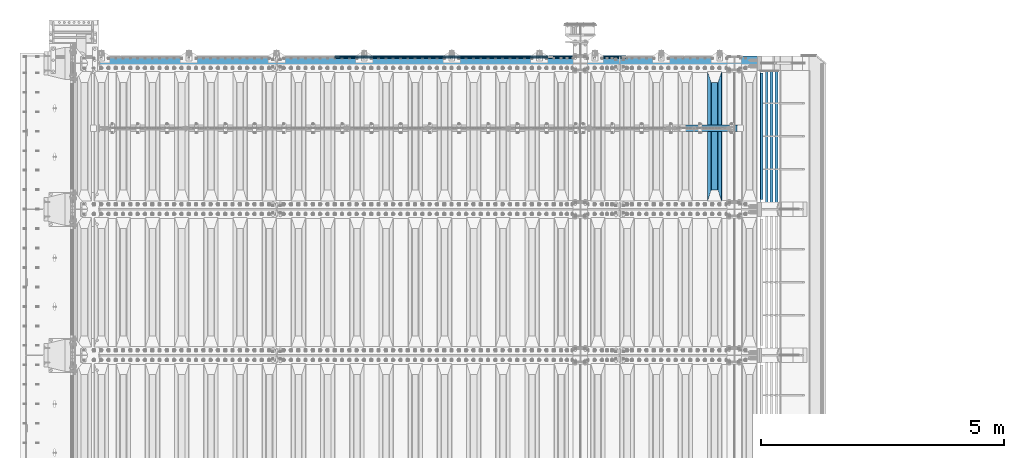
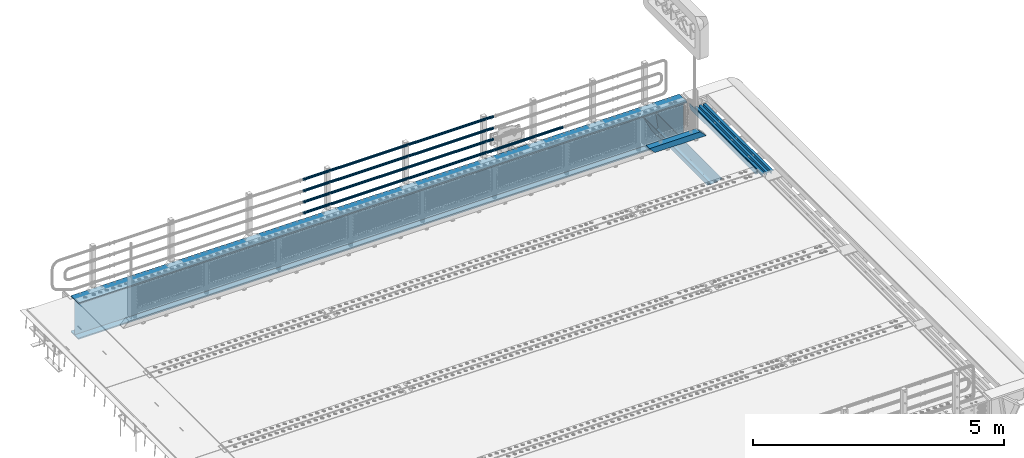
# One storey, part 126 of 240: 12 beams.
"""IFC2X3 building model written with IfcOpenShell, lengths in millimetres."""

import ifcopenshell
import ifcopenshell.guid

model = None  # the IFC model being written
_history = None  # IfcOwnerHistory: only IFC2X3 demands one
_inside = {}  # id of a spatial element -> (the spatial element, [elements in it])
_under = {}  # id of a project, library or spatial element -> (it, [spatial elements below it])
_declared = {}  # id of a project -> (the project, [libraries it declares])
_typed = {}  # id of a type object -> (the type object, [elements of that type])
_made_of = {}  # id of a material, layer set ... -> (it, [elements and type objects made of it])


def new_model(schema):
    """Start an empty IFC model of exactly this schema.

    Asked for "IFC4X3", IfcOpenShell would pick the latest addendum, in which some entities
    have other attributes; the version numbers below select the first issue.
    IFC2X3 requires an IfcOwnerHistory on every rooted entity: one is made here for all.
    """
    global model, _history
    if schema == "IFC4X3":
        model = ifcopenshell.file(schema_version=(4, 3, 0, 0))
    else:
        model = ifcopenshell.file(schema=schema)
    _inside.clear()
    _under.clear()
    _declared.clear()
    _typed.clear()
    _made_of.clear()
    _history = None
    if model.schema == "IFC2X3":
        org = make("IfcOrganization", Name="unknown")
        user = make(
            "IfcPersonAndOrganization",
            ThePerson=make("IfcPerson", FamilyName="unknown"),
            TheOrganization=org,
        )
        app = make(
            "IfcApplication",
            ApplicationDeveloper=org,
            Version="unknown",
            ApplicationFullName="unknown",
            ApplicationIdentifier="unknown",
        )
        _history = make(
            "IfcOwnerHistory",
            OwningUser=user,
            OwningApplication=app,
            ChangeAction="ADDED",
            CreationDate=0,
        )
    return model


def make(cls, **values):
    """One entity of the class cls with the attributes given. An attribute that is None is left unset."""
    return model.create_entity(
        cls, **{name: value for name, value in values.items() if value is not None}
    )


def rooted(cls, **values):
    """An entity with a GlobalId (a new one), such as an element, a storey or a relation."""
    return make(cls, GlobalId=ifcopenshell.guid.new(), OwnerHistory=_history, **values)


def si_unit(unit_type, name, prefix=None):
    """IfcSIUnit, for example si_unit("LENGTHUNIT", "METRE", prefix="MILLI")."""
    return make("IfcSIUnit", UnitType=unit_type, Prefix=prefix, Name=name)


def assignment(units):
    """IfcUnitAssignment: the units of a project."""
    return None if units is None else make("IfcUnitAssignment", Units=units)


def point(xyz):
    """IfcCartesianPoint."""
    return None if xyz is None else make("IfcCartesianPoint", Coordinates=xyz)


def direction(xyz):
    """IfcDirection."""
    return None if xyz is None else make("IfcDirection", DirectionRatios=xyz)


def frame(location, z_axis=None, x_axis=None):
    """IfcAxis2Placement3D, a coordinate frame: its origin and axes. An axis left out is left unset."""
    return make(
        "IfcAxis2Placement3D",
        Location=point(location),
        Axis=direction(z_axis),
        RefDirection=direction(x_axis),
    )


def origin_with_axes():
    """The frame at (0, 0, 0) with the z axis (0, 0, 1) and the x axis (1, 0, 0) written out."""
    return frame((0.0, 0.0, 0.0), z_axis=(0.0, 0.0, 1.0), x_axis=(1.0, 0.0, 0.0))


def place(relative_to, where):
    """IfcLocalPlacement: puts the frame where relative to a parent placement (None: the world)."""
    return make(
        "IfcLocalPlacement", PlacementRelTo=relative_to, RelativePlacement=where
    )


def context(
    kind, dimensions, precision=None, world=None, true_north=None, identifier=None
):
    """IfcGeometricRepresentationContext, for example the 3D "Model" context."""
    return make(
        "IfcGeometricRepresentationContext",
        ContextIdentifier=identifier,
        ContextType=kind,
        CoordinateSpaceDimension=dimensions,
        Precision=precision,
        WorldCoordinateSystem=world,
        TrueNorth=true_north,
    )


def subcontext(parent, identifier, kind, view, scale=None):
    """IfcGeometricRepresentationSubContext, for example "Body" below "Model"."""
    return make(
        "IfcGeometricRepresentationSubContext",
        ContextIdentifier=identifier,
        ContextType=kind,
        ParentContext=parent,
        TargetScale=scale,
        TargetView=view,
    )


def project(units=None, contexts=None):
    """IfcProject with its units and contexts."""
    return rooted(
        "IfcProject",
        Name="project",
        RepresentationContexts=contexts,
        UnitsInContext=assignment(units),
    )


def spatial(cls, under=None, at=None, **own):
    """A site, building, storey or space (cls), placed at a placement, below another one or the project."""
    s = rooted(cls, ObjectPlacement=at, **own)
    if under is not None:
        _under.setdefault(under.id(), (under, []))[1].append(s)
    return s


def faces_of(points, faces, orient=None, outer=None):
    """IfcFace entities. A face is a list of loops; a loop is a list of indices into points, from 0.

    orient and outer hold one flag for each loop. By default every Orientation is true, the
    first loop of a face is its IfcFaceOuterBound and the others are IfcFaceBound.
    """
    made = []
    for i, loops in enumerate(faces):
        bounds = []
        for j, loop in enumerate(loops):
            is_outer = j == 0 if outer is None else outer[i][j]
            bounds.append(
                make(
                    "IfcFaceOuterBound" if is_outer else "IfcFaceBound",
                    Bound=make("IfcPolyLoop", Polygon=[points[k] for k in loop]),
                    Orientation=True if orient is None else orient[i][j],
                )
            )
        made.append(make("IfcFace", Bounds=bounds))
    return made


def faceted_brep(points, faces, orient=None, outer=None, voids=None):
    """IfcFacetedBrep: a solid bounded by flat faces; with voids (closed shells), ...WithVoids."""
    shared = [point(p) for p in points]
    hull = make("IfcClosedShell", CfsFaces=faces_of(shared, faces, orient, outer))
    if voids is None:
        return make("IfcFacetedBrep", Outer=hull)
    return make(
        "IfcFacetedBrepWithVoids",
        Outer=hull,
        Voids=[
            make(cls, CfsFaces=faces_of(shared, fs, o, b)) for cls, fs, o, b in voids
        ],
    )


def shape(context_of_items, identifier, shape_type, items):
    """IfcShapeRepresentation: the items that make up one representation, for example the "Body"."""
    return make(
        "IfcShapeRepresentation",
        ContextOfItems=context_of_items,
        RepresentationIdentifier=identifier,
        RepresentationType=shape_type,
        Items=items,
    )


def material(Name=None, Category=None):
    """IfcMaterial."""
    return make("IfcMaterial", Name=Name, Category=Category)


def made_of(thing, what):
    """Note that an element or type object is made of a material, layer set ...; save() writes the relation."""
    if what is not None:
        _made_of.setdefault(what.id(), (what, []))[1].append(thing)
    return thing


def type_object(cls, material=None, **own):
    """A type object (cls), such as IfcWallType, which elements share."""
    return made_of(rooted(cls, **own), material)


def element(
    cls,
    number,
    at=None,
    inside=None,
    cuts=None,
    type_object=None,
    material=None,
    context=None,
    identifier="Body",
    shape_type=None,
    held_by="IfcProductDefinitionShape",
    body=None,
    shapes=None,
    **own,
):
    """One element of the class cls, such as IfcWall. Its Tag is "e" and its number.

    at: its placement. inside: the storey or other place that contains it. cuts: it is an
    opening in that element (IfcRelVoidsElement). A single representation is given by context,
    identifier, shape_type and body (its items); several are given by shapes. held_by: the class
    of the entity that holds the representations. save() writes the other relations.
    """
    e = rooted(cls, Tag="e%d" % number, ObjectPlacement=at, **own)
    if body is not None:
        shapes = [shape(context, identifier, shape_type, body)]
    if shapes is not None:
        e.Representation = make(held_by, Representations=shapes)
    if inside is not None:
        _inside.setdefault(inside.id(), (inside, []))[1].append(e)
    if cuts is not None:
        rooted(
            "IfcRelVoidsElement", RelatingBuildingElement=cuts, RelatedOpeningElement=e
        )
    if type_object is not None:
        _typed.setdefault(type_object.id(), (type_object, []))[1].append(e)
    return made_of(e, material)


def aggregate(whole, parts):
    """IfcRelAggregates: a whole, such as a stair, and the parts it consists of."""
    return rooted("IfcRelAggregates", RelatingObject=whole, RelatedObjects=parts)


def save(model, path):
    """Write the relations noted so far, then the file.

    IfcRelAggregates (storeys below a building ...), IfcRelContainedInSpatialStructure (elements
    in a storey), IfcRelDefinesByType, IfcRelAssociatesMaterial and IfcRelDeclares: one each for
    every whole, place, type object, material and project.
    """
    for whole, parts in _under.values():
        aggregate(whole, parts)
    for where, things in _inside.values():
        rooted(
            "IfcRelContainedInSpatialStructure",
            RelatedElements=things,
            RelatingStructure=where,
        )
    for kind, things in _typed.values():
        rooted("IfcRelDefinesByType", RelatedObjects=things, RelatingType=kind)
    for what, things in _made_of.values():
        rooted("IfcRelAssociatesMaterial", RelatedObjects=things, RelatingMaterial=what)
    for by, libraries in _declared.values():
        rooted("IfcRelDeclares", RelatingContext=by, RelatedDefinitions=libraries)
    model.write(path)


model = new_model("IFC2X3")

# Units and contexts
model_context = context("Model", 3, precision=1e-05, world=origin_with_axes())
body_context = subcontext(model_context, "Body", "Model", "MODEL_VIEW")
ifc_project = project(units=[si_unit("LENGTHUNIT", "METRE", prefix="MILLI"), si_unit("AREAUNIT", "SQUARE_METRE"), si_unit("VOLUMEUNIT", "CUBIC_METRE"), si_unit("MASSUNIT", "GRAM", prefix="KILO"), si_unit("TIMEUNIT", "SECOND"), si_unit("PLANEANGLEUNIT", "RADIAN"), si_unit("SOLIDANGLEUNIT", "STERADIAN"), si_unit("THERMODYNAMICTEMPERATUREUNIT", "DEGREE_CELSIUS"), si_unit("LUMINOUSINTENSITYUNIT", "LUMEN")], contexts=[model_context])

# Site, building, storey
site_placement = place(None, origin_with_axes())
site = spatial("IfcSite", under=ifc_project, at=site_placement, CompositionType="ELEMENT")
building_placement = place(site_placement, origin_with_axes())
building = spatial("IfcBuilding", under=site, at=building_placement, Name="Standard", CompositionType="ELEMENT")
storey_placement = place(building_placement, origin_with_axes())
storey = spatial("IfcBuildingStorey", under=building, at=storey_placement, Name="Undefined", CompositionType="ELEMENT", Elevation=0.0)

# Beams
ifc_material_1 = material(Name="STEEL/S355N")
beam_type_1 = type_object("IfcBeamType", PredefinedType="NOTDEFINED")
beam_1_placement = place(storey_placement, frame((55600.0, 33175.0, -115.0), z_axis=(0.0, 0.0, 1.0), x_axis=(0.0, 1.0, 0.0)))
element("IfcBeam", 1, at=beam_1_placement, inside=storey, type_object=beam_type_1, material=ifc_material_1, context=body_context, shape_type="Brep", body=[
    faceted_brep([(0.0, 150.0, 115.0), (0.0, 143.690000000002, 115.0), (2650.00000000297, 143.690000000002, 115.0), (2650.00000000297, 150.0, 115.0), (2650.00000000297, 142.059565218406, 110.000000003094), (2650.00000000297, 148.369565218403, 110.000000003094), (2441.90079219209, -80.1103600731149, -98.0992078077845), (2437.7588105432, -77.5672621345584, -102.241189456673), (2434.06523489747, -74.4080125315522, -105.934765102404), (2430.9108609509, -70.7102721255724, -109.089139048974), (2428.37322971128, -66.5649389910031, -111.626770288588), (2426.51472138055, -62.0739139532889, -113.485278619323), (2425.38102192092, -57.3475956567636, -114.618978078955), (2424.99999999987, -52.5021667386536, -115.0), (2424.99999999987, 52.5021667386536, -115.0), (2425.38102192092, 57.3475956567636, -114.618978078955), (2426.51472138055, 62.0739139532889, -113.485278619323), (2428.37322971128, 66.5649389910031, -111.626770288588), (2430.9108609509, 70.7102721255724, -109.089139048974), (2434.06523489747, 74.4080125315522, -105.934765102404), (2437.7588105432, 77.5672621345584, -102.241189456673), (2441.90079219209, 80.1103600731149, -98.0992078077846), (2446.38936140512, 81.9747917625791, -93.6106385947584), (2448.2494850041, 76.2713538057287, -91.7505149957729), (2444.62967112263, 74.76777986261, -95.3703288772456), (2441.28936334127, 72.7168944282894, -98.710636658607), (2438.31067330439, 70.1691124903809, -101.689326695487), (2435.76682334748, 67.1870637758839, -104.233176652398), (2433.72034654134, 63.8440531834931, -106.279653458539), (2432.22154950042, 60.2222587982324, -107.778450499454), (2431.30727574265, 56.4107117849126, -108.692724257221), (2430.99999999987, 52.5031078186876, -109.0), (2430.99999999987, -52.5031078186876, -109.0), (2431.30727574265, -56.4107117849126, -108.692724257221), (2432.22154950042, -60.2222587982324, -107.778450499454), (2433.72034654134, -63.8440531834931, -106.279653458539), (2435.76682334748, -67.1870637758839, -104.233176652398), (2438.31067330439, -70.1691124903809, -101.689326695487), (2441.28936334127, -72.7168944282894, -98.7106366586071), (2444.62967112263, -74.76777986261, -95.3703288772457), (2448.2494850041, -76.2713538057287, -91.7505149957729), (2650.00000000297, -142.059565218406, 110.000000003094), (2650.00000000297, -148.369565218403, 110.000000003094), (2446.38936140512, -81.9747917625791, -93.6106385947584), (2650.00000000297, -143.690000000002, 115.0), (2650.00000000297, -150.0, 115.0), (0.0, -143.690000000002, 115.0), (0.0, -150.0, 115.0), (0.0, -148.369565218258, 110.000000002667), (203.610638597427, -81.9747917625791, -93.6106385947584), (208.09920781045, -80.1103600731149, -98.0992078077845), (212.241189459342, -77.5672621345584, -102.241189456673), (215.93476510507, -74.4080125315522, -105.934765102404), (219.089139051641, -70.7102721255724, -109.089139048974), (221.626770291256, -66.5649389910031, -111.626770288588), (223.485278621989, -62.0739139532889, -113.485278619323), (224.618978081624, -57.3475956567636, -114.618978078955), (225.000000002663, -52.5021667386536, -115.0), (225.000000002663, 52.5021667386536, -115.0), (224.618978081624, 57.3475956567636, -114.618978078955), (223.485278621989, 62.0739139532889, -113.485278619323), (221.626770291256, 66.5649389910031, -111.626770288588), (219.089139051641, 70.7102721255724, -109.089139048974), (215.93476510507, 74.4080125315522, -105.934765102404), (212.241189459342, 77.5672621345584, -102.241189456673), (208.09920781045, 80.1103600731149, -98.0992078077846), (203.610638597427, 81.9747917625791, -93.6106385947584), (0.0, 148.369565218258, 110.000000002667), (0.0, 142.05956521826, 110.000000002667), (201.750514998439, 76.2713538057287, -91.7505149957729), (205.370328879908, 74.76777986261, -95.3703288772456), (208.710636661275, 72.7168944282894, -98.710636658607), (211.689326698153, 70.1691124903809, -101.689326695487), (214.233176655063, 67.1870637758839, -104.233176652398), (216.279653461206, 63.8440531834931, -106.279653458539), (217.778450502123, 60.2222587982324, -107.778450499454), (218.692724259887, 56.4107117849126, -108.692724257221), (219.000000002667, 52.5031078186876, -109.0), (219.000000002667, -52.5031078186876, -109.0), (218.692724259887, -56.4107117849126, -108.692724257221), (217.778450502123, -60.2222587982324, -107.778450499454), (216.279653461206, -63.8440531834931, -106.279653458539), (214.233176655063, -67.1870637758839, -104.233176652398), (211.689326698153, -70.1691124903809, -101.689326695487), (208.710636661275, -72.7168944282894, -98.7106366586071), (205.370328879915, -74.76777986261, -95.3703288772457), (201.750514998439, -76.2713538057287, -91.7505149957729), (0.0, -142.05956521826, 110.000000002667)], [[[0, 1, 2, 3]], [[3, 2, 4, 5]], [[6, 7, 8, 9, 10, 11, 12, 13, 14, 15, 16, 17, 18, 19, 20, 21, 22, 5, 4, 23, 24, 25, 26, 27, 28, 29, 30, 31, 32, 33, 34, 35, 36, 37, 38, 39, 40, 41, 42, 43]], [[44, 45, 42, 41]], [[46, 47, 45, 44]], [[43, 42, 45, 47, 48, 49]], [[6, 43, 49, 50]], [[7, 6, 50, 51]], [[8, 7, 51, 52]], [[9, 8, 52, 53]], [[10, 9, 53, 54]], [[11, 10, 54, 55]], [[12, 11, 55, 56]], [[13, 12, 56, 57]], [[14, 13, 57, 58]], [[15, 14, 58, 59]], [[16, 15, 59, 60]], [[17, 16, 60, 61]], [[18, 17, 61, 62]], [[19, 18, 62, 63]], [[20, 19, 63, 64]], [[21, 20, 64, 65]], [[22, 21, 65, 66]], [[0, 3, 5, 22, 66, 67]], [[1, 0, 67, 68]], [[23, 4, 2, 1, 68, 69]], [[24, 23, 69, 70]], [[25, 24, 70, 71]], [[26, 25, 71, 72]], [[27, 26, 72, 73]], [[28, 27, 73, 74]], [[29, 28, 74, 75]], [[30, 29, 75, 76]], [[31, 30, 76, 77]], [[32, 31, 77, 78]], [[33, 32, 78, 79]], [[34, 33, 79, 80]], [[35, 34, 80, 81]], [[36, 35, 81, 82]], [[37, 36, 82, 83]], [[38, 37, 83, 84]], [[39, 38, 84, 85]], [[40, 39, 85, 86]], [[46, 44, 41, 40, 86, 87]], [[47, 46, 87, 48]], [[86, 85, 84, 83, 82, 81, 80, 79, 78, 77, 76, 75, 74, 73, 72, 71, 70, 69, 68, 67, 66, 65, 64, 63, 62, 61, 60, 59, 58, 57, 56, 55, 54, 53, 52, 51, 50, 49, 48, 87]]]),
])
ifc_material_2 = material()
beam_type_2 = type_object("IfcBeamType", PredefinedType="NOTDEFINED")
beam_2_placement = place(storey_placement, frame((54887.0, 34664.5, 98.0199999999977), z_axis=(0.0, 0.0, 1.0), x_axis=(1.0, 0.0, 0.0)))
element("IfcBeam", 2, at=beam_2_placement, inside=storey, type_object=beam_type_2, material=ifc_material_2, context=body_context, shape_type="Brep", body=[
    faceted_brep([(0.0, 70.0, 70.0), (0.0, -70.0, 70.0), (1170.88846984783, -70.0, 70.0), (1170.88846984783, 70.0, 70.0), (1301.0, -60.0, -60.0), (1301.0, 60.0, -60.0), (119.989831466432, 60.0, -60.0), (119.989910626158, -60.0, -60.0), (1180.89643628727, -60.0, 60.0), (2.49929144047201e-09, -60.0, 60.0), (2.49929144047201e-09, 60.0000000000036, 60.0), (1180.89643628727, 60.0, 60.0), (1301.0, -70.0, -60.0079600980695), (1301.0, 70.0, -60.0079600980695), (1301.0, -70.0, -70.0), (1301.0, 70.0, -70.0), (129.999907566664, 70.0, -70.0), (0.0, 70.0, 59.8689646261474), (0.0, -70.0, 59.8690568861467), (129.999999919688, -70.0, -70.0)], [[[0, 1, 2, 3]], [[4, 5, 6, 7]], [[8, 4, 7, 9]], [[9, 10, 11, 8]], [[5, 11, 10, 6]], [[2, 12, 4, 8, 11, 5, 13, 3]], [[4, 12, 14, 15, 13, 5]], [[0, 3, 13, 15, 16, 17]], [[9, 18, 1, 0, 17, 10]], [[14, 12, 2, 1, 18, 19]], [[15, 14, 19, 16]], [[18, 9, 7, 6, 10, 17, 16, 19]]]),
])
ifc_material_3 = material(Name="STEEL/S355J2")
beam_type_3 = type_object("IfcBeamType", PredefinedType="NOTDEFINED")
beam_3_placement = place(storey_placement, frame((56564.5025260065, 33150.0, -124.999999999993), z_axis=(0.0, 0.0, 1.0), x_axis=(0.0, 1.0, 0.0)))
element("IfcBeam", 3, at=beam_3_placement, inside=storey, type_object=beam_type_3, material=ifc_material_3, context=body_context, shape_type="Brep", body=[
    faceted_brep([(2700.0, 22.5, -15.0), (2684.54915028125, 22.5, -17.4471741852423), (2684.54915028125, 32.4999999999927, -17.4471741852423), (2700.0, 32.5, -15.0), (2670.61073738538, 22.5, -24.5491502812526), (2670.61073738538, 32.4999999999927, -24.5491502812526), (2659.54915028125, 22.5, -35.6107373853764), (2659.54915028125, 32.4999999999927, -35.6107373853764), (2652.44717418524, 22.5, -49.5491502812526), (2652.44717418524, 32.4999999999927, -49.5491502812526), (2651.58384440325, -32.5, -55.0), (2650.0, -32.5, -65.0), (2650.0, 32.5, -65.0), (2651.58384440325, 22.5, -55.0), (0.0, 32.5, 65.0), (0.0, 22.5, 65.0), (2700.0, 22.5, 65.0), (2700.0, 32.5, 65.0), (0.0, 32.5, -15.0), (0.0, 22.5, -15.0), (15.4508497187489, 32.5, -17.4471741852423), (15.4508497187489, 22.5, -17.4471741852423), (29.3892626146226, 32.5, -24.5491502812526), (29.3892626146226, 22.5, -24.5491502812526), (40.4508497187489, 32.5, -35.6107373853763), (40.4508497187489, 22.5, -35.6107373853763), (47.5528258147569, 32.5, -49.5491502812526), (47.5528258147569, 22.5, -49.5491502812526), (50.0, -32.5, -65.0), (48.4161555967512, -32.5, -55.0), (48.4161555967512, 22.5, -55.0), (50.0, 32.5, -65.0)], [[[0, 1, 2, 3]], [[4, 5, 2, 1]], [[6, 7, 5, 4]], [[8, 9, 7, 6]], [[10, 11, 12, 9, 8, 13]], [[14, 15, 16, 17]], [[15, 14, 18, 19]], [[19, 18, 20, 21]], [[21, 20, 22, 23]], [[23, 22, 24, 25]], [[25, 24, 26, 27]], [[28, 29, 30, 27, 26, 31]], [[30, 29, 10, 13]], [[16, 15, 19, 21, 23, 25, 27, 30, 13, 8, 6, 4, 1, 0]], [[17, 16, 0, 3]], [[5, 7, 9, 12, 31, 26, 24, 22, 20, 18, 14, 17, 3, 2]], [[28, 31, 12, 11]], [[29, 28, 11, 10]]]),
])
beam_type_4 = type_object("IfcBeamType", PredefinedType="NOTDEFINED")
beam_4_placement = place(storey_placement, frame((52177.9999999999, 36129.8500000001, 149.849999999748), z_axis=(0.0, 0.0, -1.0), x_axis=(-1.0, 0.0, 0.0)))
element("IfcBeam", 4, at=beam_4_placement, inside=storey, type_object=beam_type_4, material=ifc_material_2, context=body_context, shape_type="Brep", body=[
    faceted_brep([(0.0, -26.5500000000029, 0.0), (0.0, -24.5290015881765, 10.1602451292931), (4384.00249699992, -24.5290015881765, 10.1602451292931), (4384.00249699992, -26.5500000000029, 0.0), (0.0, -18.7736850405054, 18.7736850405028), (4384.00249699992, -18.7736850405054, 18.7736850405028), (0.0, -10.1602451292929, 24.5290015881747), (4384.00249699992, -10.1602451292929, 24.5290015881747), (0.0, 0.0, 26.55), (4384.00249699992, 0.0, 26.55), (0.0, 10.1602451292929, 24.5290015881747), (4384.00249699992, 10.1602451292929, 24.5290015881747), (0.0, 18.7736850405054, 18.7736850405028), (4384.00249699992, 18.7736850405054, 18.7736850405028), (0.0, 24.5290015881765, 10.1602451292931), (4384.00249699992, 24.5290015881765, 10.1602451292931), (0.0, 26.5500000000029, 0.0), (4384.00249699992, 26.5500000000029, 0.0), (0.0, 24.5290015881765, -10.1602451292931), (4384.00249699992, 24.5290015881765, -10.1602451292931), (0.0, 18.7736850405054, -18.7736850405028), (4384.00249699992, 18.7736850405054, -18.7736850405028), (0.0, 10.1602451292929, -24.5290015881747), (4384.00249699992, 10.1602451292929, -24.5290015881747), (0.0, 0.0, -26.55), (4384.00249699992, 0.0, -26.55), (0.0, -10.1602451292929, -24.5290015881747), (4384.00249699992, -10.1602451292929, -24.5290015881747), (0.0, -18.7736850405054, -18.7736850405028), (4384.00249699992, -18.7736850405054, -18.7736850405028), (0.0, -24.5290015881765, -10.1602451292931), (4384.00249699992, -24.5290015881765, -10.1602451292931), (0.0, -30.1500000000015, 0.0), (0.0, -27.8549679052157, -11.5379054858058), (4384.00249699992, -27.8549679052157, -11.5379054858075), (4384.00249699992, -30.1500000000015, 0.0), (0.0, -21.3192694527752, -21.3192694527752), (4384.00249699992, -21.3192694527752, -21.3192694527744), (0.0, -11.5379054858058, -27.8549679052157), (4384.00249699992, -11.5379054858058, -27.8549679052153), (0.0, 0.0, -30.1500000000015), (4384.00249699992, 0.0, -30.15), (0.0, 11.5379054858058, -27.8549679052157), (4384.00249699992, 11.5379054858058, -27.8549679052153), (0.0, 21.3192694527752, -21.3192694527752), (4384.00249699992, 21.3192694527752, -21.3192694527744), (0.0, 27.8549679052157, -11.5379054858058), (4384.00249699992, 27.8549679052157, -11.5379054858074), (0.0, 30.1500000000015, 0.0), (4384.00249699992, 30.1500000000015, 0.0), (0.0, 27.8549679052157, 11.5379054858058), (4384.00249699992, 27.8549679052157, 11.5379054858075), (0.0, 21.3192694527752, 21.3192694527752), (4384.00249699992, 21.3192694527752, 21.3192694527744), (0.0, 11.5379054858058, 27.8549679052157), (4384.00249699992, 11.5379054858058, 27.8549679052153), (0.0, 0.0, 30.1500000000015), (4384.00249699992, 0.0, 30.15), (0.0, -11.5379054858058, 27.8549679052157), (4384.00249699992, -11.5379054858058, 27.8549679052153), (0.0, -21.3192694527752, 21.3192694527752), (4384.00249699992, -21.3192694527752, 21.3192694527744), (0.0, -27.8549679052157, 11.5379054858058), (4384.00249699992, -27.8549679052157, 11.5379054858075)], [[[0, 1, 2, 3]], [[1, 4, 5, 2]], [[4, 6, 7, 5]], [[6, 8, 9, 7]], [[8, 10, 11, 9]], [[10, 12, 13, 11]], [[12, 14, 15, 13]], [[14, 16, 17, 15]], [[16, 18, 19, 17]], [[18, 20, 21, 19]], [[20, 22, 23, 21]], [[22, 24, 25, 23]], [[24, 26, 27, 25]], [[26, 28, 29, 27]], [[28, 30, 31, 29]], [[30, 0, 3, 31]], [[32, 33, 34, 35]], [[33, 36, 37, 34]], [[36, 38, 39, 37]], [[38, 40, 41, 39]], [[40, 42, 43, 41]], [[42, 44, 45, 43]], [[44, 46, 47, 45]], [[46, 48, 49, 47]], [[48, 50, 51, 49]], [[50, 52, 53, 51]], [[52, 54, 55, 53]], [[54, 56, 57, 55]], [[56, 58, 59, 57]], [[58, 60, 61, 59]], [[60, 62, 63, 61]], [[62, 32, 35, 63]], [[37, 39, 41, 43, 45, 47, 49, 51, 53, 55, 57, 59, 61, 63, 35, 34], [5, 7, 9, 11, 13, 15, 17, 19, 21, 23, 25, 27, 29, 31, 3, 2]], [[62, 60, 58, 56, 54, 52, 50, 48, 46, 44, 42, 40, 38, 36, 33, 32], [30, 28, 26, 24, 22, 20, 18, 16, 14, 12, 10, 8, 6, 4, 1, 0]]]),
])
beam_5_placement = place(storey_placement, frame((53781.9999999999, 36129.8500000002, 149.849999999748), z_axis=(0.0, 0.0, -1.0), x_axis=(-1.0, 0.0, 0.0)))
element("IfcBeam", 5, at=beam_5_placement, inside=storey, type_object=beam_type_4, material=ifc_material_2, context=body_context, shape_type="Brep", body=[
    faceted_brep([(0.0, -26.5500000000029, 0.0), (0.0, -24.5290015881765, 10.1602451292931), (1594.0, -24.5290015881765, 10.1602451292931), (1594.0, -26.5500000000029, 0.0), (0.0, -18.7736850405054, 18.7736850405028), (1594.0, -18.7736850405054, 18.7736850405028), (0.0, -10.1602451292929, 24.5290015881747), (1594.0, -10.1602451292929, 24.5290015881747), (0.0, 0.0, 26.55), (1594.0, 0.0, 26.55), (0.0, 10.1602451292929, 24.5290015881747), (1594.0, 10.1602451292929, 24.5290015881747), (0.0, 18.7736850405054, 18.7736850405028), (1594.0, 18.7736850405054, 18.7736850405028), (0.0, 24.5290015881765, 10.1602451292931), (1594.0, 24.5290015881765, 10.1602451292931), (0.0, 26.5500000000029, 0.0), (1594.0, 26.5500000000029, 0.0), (0.0, 24.5290015881765, -10.1602451292931), (1594.0, 24.5290015881765, -10.1602451292931), (0.0, 18.7736850405054, -18.7736850405028), (1594.0, 18.7736850405054, -18.7736850405028), (0.0, 10.1602451292929, -24.5290015881747), (1594.0, 10.1602451292929, -24.5290015881747), (0.0, 0.0, -26.55), (1594.0, 0.0, -26.55), (0.0, -10.1602451292929, -24.5290015881747), (1594.0, -10.1602451292929, -24.5290015881747), (0.0, -18.7736850405054, -18.7736850405028), (1594.0, -18.7736850405054, -18.7736850405028), (0.0, -24.5290015881765, -10.1602451292931), (1594.0, -24.5290015881765, -10.1602451292931), (0.0, -30.1500000000015, 0.0), (0.0, -27.8549679052157, -11.5379054858058), (1594.0, -27.8549679052157, -11.5379054858075), (1594.0, -30.1500000000015, 0.0), (0.0, -21.3192694527752, -21.3192694527752), (1594.0, -21.3192694527752, -21.3192694527744), (0.0, -11.5379054858058, -27.8549679052157), (1594.0, -11.5379054858058, -27.8549679052153), (0.0, 0.0, -30.1500000000015), (1594.0, 0.0, -30.15), (0.0, 11.5379054858058, -27.8549679052157), (1594.0, 11.5379054858058, -27.8549679052153), (0.0, 21.3192694527752, -21.3192694527752), (1594.0, 21.3192694527752, -21.3192694527744), (0.0, 27.8549679052157, -11.5379054858058), (1594.0, 27.8549679052157, -11.5379054858074), (0.0, 30.1500000000015, 0.0), (1594.0, 30.1500000000015, 0.0), (0.0, 27.8549679052157, 11.5379054858058), (1594.0, 27.8549679052157, 11.5379054858075), (0.0, 21.3192694527752, 21.3192694527752), (1594.0, 21.3192694527752, 21.3192694527744), (0.0, 11.5379054858058, 27.8549679052157), (1594.0, 11.5379054858058, 27.8549679052153), (0.0, 0.0, 30.1500000000015), (1594.0, 0.0, 30.15), (0.0, -11.5379054858058, 27.8549679052157), (1594.0, -11.5379054858058, 27.8549679052153), (0.0, -21.3192694527752, 21.3192694527752), (1594.0, -21.3192694527752, 21.3192694527744), (0.0, -27.8549679052157, 11.5379054858058), (1594.0, -27.8549679052157, 11.5379054858075)], [[[0, 1, 2, 3]], [[1, 4, 5, 2]], [[4, 6, 7, 5]], [[6, 8, 9, 7]], [[8, 10, 11, 9]], [[10, 12, 13, 11]], [[12, 14, 15, 13]], [[14, 16, 17, 15]], [[16, 18, 19, 17]], [[18, 20, 21, 19]], [[20, 22, 23, 21]], [[22, 24, 25, 23]], [[24, 26, 27, 25]], [[26, 28, 29, 27]], [[28, 30, 31, 29]], [[30, 0, 3, 31]], [[32, 33, 34, 35]], [[33, 36, 37, 34]], [[36, 38, 39, 37]], [[38, 40, 41, 39]], [[40, 42, 43, 41]], [[42, 44, 45, 43]], [[44, 46, 47, 45]], [[46, 48, 49, 47]], [[48, 50, 51, 49]], [[50, 52, 53, 51]], [[52, 54, 55, 53]], [[54, 56, 57, 55]], [[56, 58, 59, 57]], [[58, 60, 61, 59]], [[60, 62, 63, 61]], [[62, 32, 35, 63]], [[37, 39, 41, 43, 45, 47, 49, 51, 53, 55, 57, 59, 61, 63, 35, 34], [5, 7, 9, 11, 13, 15, 17, 19, 21, 23, 25, 27, 29, 31, 3, 2]], [[62, 60, 58, 56, 54, 52, 50, 48, 46, 44, 42, 40, 38, 36, 33, 32], [30, 28, 26, 24, 22, 20, 18, 16, 14, 12, 10, 8, 6, 4, 1, 0]]]),
])
beam_6_placement = place(storey_placement, frame((52177.9999999999, 36129.8500000001, 420.149999999748), z_axis=(0.0, 0.0, -1.0), x_axis=(-1.0, 0.0, 0.0)))
element("IfcBeam", 6, at=beam_6_placement, inside=storey, type_object=beam_type_4, material=ifc_material_2, context=body_context, shape_type="Brep", body=[
    faceted_brep([(0.0, -26.5500000000029, 0.0), (0.0, -24.5290015881765, 10.1602451292931), (4384.00249699992, -24.5290015881765, 10.1602451292931), (4384.00249699992, -26.5500000000029, 0.0), (0.0, -18.7736850405054, 18.7736850405028), (4384.00249699992, -18.7736850405054, 18.7736850405028), (0.0, -10.1602451292929, 24.5290015881747), (4384.00249699992, -10.1602451292929, 24.5290015881747), (0.0, 0.0, 26.55), (4384.00249699992, 0.0, 26.55), (0.0, 10.1602451292929, 24.5290015881747), (4384.00249699992, 10.1602451292929, 24.5290015881747), (0.0, 18.7736850405054, 18.7736850405028), (4384.00249699992, 18.7736850405054, 18.7736850405028), (0.0, 24.5290015881765, 10.1602451292931), (4384.00249699992, 24.5290015881765, 10.1602451292931), (0.0, 26.5500000000029, 0.0), (4384.00249699992, 26.5500000000029, 0.0), (0.0, 24.5290015881765, -10.1602451292931), (4384.00249699992, 24.5290015881765, -10.1602451292931), (0.0, 18.7736850405054, -18.7736850405028), (4384.00249699992, 18.7736850405054, -18.7736850405028), (0.0, 10.1602451292929, -24.5290015881747), (4384.00249699992, 10.1602451292929, -24.5290015881747), (0.0, 0.0, -26.55), (4384.00249699992, 0.0, -26.55), (0.0, -10.1602451292929, -24.5290015881747), (4384.00249699992, -10.1602451292929, -24.5290015881747), (0.0, -18.7736850405054, -18.7736850405028), (4384.00249699992, -18.7736850405054, -18.7736850405028), (0.0, -24.5290015881765, -10.1602451292931), (4384.00249699992, -24.5290015881765, -10.1602451292931), (0.0, -30.1500000000015, 0.0), (0.0, -27.8549679052157, -11.5379054858058), (4384.00249699992, -27.8549679052157, -11.5379054858075), (4384.00249699992, -30.1500000000015, 0.0), (0.0, -21.3192694527752, -21.3192694527752), (4384.00249699992, -21.3192694527752, -21.3192694527744), (0.0, -11.5379054858058, -27.8549679052157), (4384.00249699992, -11.5379054858058, -27.8549679052153), (0.0, 0.0, -30.1500000000015), (4384.00249699992, 0.0, -30.15), (0.0, 11.5379054858058, -27.8549679052157), (4384.00249699992, 11.5379054858058, -27.8549679052153), (0.0, 21.3192694527752, -21.3192694527752), (4384.00249699992, 21.3192694527752, -21.3192694527744), (0.0, 27.8549679052157, -11.5379054858058), (4384.00249699992, 27.8549679052157, -11.5379054858074), (0.0, 30.1500000000015, 0.0), (4384.00249699992, 30.1500000000015, 0.0), (0.0, 27.8549679052157, 11.5379054858058), (4384.00249699992, 27.8549679052157, 11.5379054858075), (0.0, 21.3192694527752, 21.3192694527752), (4384.00249699992, 21.3192694527752, 21.3192694527744), (0.0, 11.5379054858058, 27.8549679052157), (4384.00249699992, 11.5379054858058, 27.8549679052153), (0.0, 0.0, 30.1500000000015), (4384.00249699992, 0.0, 30.15), (0.0, -11.5379054858058, 27.8549679052157), (4384.00249699992, -11.5379054858058, 27.8549679052153), (0.0, -21.3192694527752, 21.3192694527752), (4384.00249699992, -21.3192694527752, 21.3192694527744), (0.0, -27.8549679052157, 11.5379054858058), (4384.00249699992, -27.8549679052157, 11.5379054858075)], [[[0, 1, 2, 3]], [[1, 4, 5, 2]], [[4, 6, 7, 5]], [[6, 8, 9, 7]], [[8, 10, 11, 9]], [[10, 12, 13, 11]], [[12, 14, 15, 13]], [[14, 16, 17, 15]], [[16, 18, 19, 17]], [[18, 20, 21, 19]], [[20, 22, 23, 21]], [[22, 24, 25, 23]], [[24, 26, 27, 25]], [[26, 28, 29, 27]], [[28, 30, 31, 29]], [[30, 0, 3, 31]], [[32, 33, 34, 35]], [[33, 36, 37, 34]], [[36, 38, 39, 37]], [[38, 40, 41, 39]], [[40, 42, 43, 41]], [[42, 44, 45, 43]], [[44, 46, 47, 45]], [[46, 48, 49, 47]], [[48, 50, 51, 49]], [[50, 52, 53, 51]], [[52, 54, 55, 53]], [[54, 56, 57, 55]], [[56, 58, 59, 57]], [[58, 60, 61, 59]], [[60, 62, 63, 61]], [[62, 32, 35, 63]], [[37, 39, 41, 43, 45, 47, 49, 51, 53, 55, 57, 59, 61, 63, 35, 34], [5, 7, 9, 11, 13, 15, 17, 19, 21, 23, 25, 27, 29, 31, 3, 2]], [[62, 60, 58, 56, 54, 52, 50, 48, 46, 44, 42, 40, 38, 36, 33, 32], [30, 28, 26, 24, 22, 20, 18, 16, 14, 12, 10, 8, 6, 4, 1, 0]]]),
])
beam_7_placement = place(storey_placement, frame((52177.9999999999, 36129.8500000001, 969.849999999748), z_axis=(0.0, 0.0, -1.0), x_axis=(-1.0, 0.0, 0.0)))
element("IfcBeam", 7, at=beam_7_placement, inside=storey, type_object=beam_type_4, material=ifc_material_2, context=body_context, shape_type="Brep", body=[
    faceted_brep([(0.0, -26.5500000000029, 0.0), (0.0, -24.5290015881765, 10.1602451292931), (4384.00249699992, -24.5290015881765, 10.1602451292931), (4384.00249699992, -26.5500000000029, 0.0), (0.0, -18.7736850405054, 18.7736850405028), (4384.00249699992, -18.7736850405054, 18.7736850405028), (0.0, -10.1602451292929, 24.5290015881747), (4384.00249699992, -10.1602451292929, 24.5290015881747), (0.0, 0.0, 26.55), (4384.00249699992, 0.0, 26.55), (0.0, 10.1602451292929, 24.5290015881747), (4384.00249699992, 10.1602451292929, 24.5290015881747), (0.0, 18.7736850405054, 18.7736850405028), (4384.00249699992, 18.7736850405054, 18.7736850405028), (0.0, 24.5290015881765, 10.1602451292931), (4384.00249699992, 24.5290015881765, 10.1602451292931), (0.0, 26.5500000000029, 0.0), (4384.00249699992, 26.5500000000029, 0.0), (0.0, 24.5290015881765, -10.1602451292931), (4384.00249699992, 24.5290015881765, -10.1602451292931), (0.0, 18.7736850405054, -18.7736850405028), (4384.00249699992, 18.7736850405054, -18.7736850405028), (0.0, 10.1602451292929, -24.5290015881747), (4384.00249699992, 10.1602451292929, -24.5290015881747), (0.0, 0.0, -26.55), (4384.00249699992, 0.0, -26.55), (0.0, -10.1602451292929, -24.5290015881747), (4384.00249699992, -10.1602451292929, -24.5290015881747), (0.0, -18.7736850405054, -18.7736850405028), (4384.00249699992, -18.7736850405054, -18.7736850405028), (0.0, -24.5290015881765, -10.1602451292931), (4384.00249699992, -24.5290015881765, -10.1602451292931), (0.0, -30.1500000000015, 0.0), (0.0, -27.8549679052157, -11.5379054858058), (4384.00249699992, -27.8549679052157, -11.5379054858075), (4384.00249699992, -30.1500000000015, 0.0), (0.0, -21.3192694527752, -21.3192694527752), (4384.00249699992, -21.3192694527752, -21.3192694527744), (0.0, -11.5379054858058, -27.8549679052157), (4384.00249699992, -11.5379054858058, -27.8549679052153), (0.0, 0.0, -30.1500000000015), (4384.00249699992, 0.0, -30.15), (0.0, 11.5379054858058, -27.8549679052157), (4384.00249699992, 11.5379054858058, -27.8549679052153), (0.0, 21.3192694527752, -21.3192694527752), (4384.00249699992, 21.3192694527752, -21.3192694527744), (0.0, 27.8549679052157, -11.5379054858058), (4384.00249699992, 27.8549679052157, -11.5379054858074), (0.0, 30.1500000000015, 0.0), (4384.00249699992, 30.1500000000015, 0.0), (0.0, 27.8549679052157, 11.5379054858058), (4384.00249699992, 27.8549679052157, 11.5379054858075), (0.0, 21.3192694527752, 21.3192694527752), (4384.00249699992, 21.3192694527752, 21.3192694527744), (0.0, 11.5379054858058, 27.8549679052157), (4384.00249699992, 11.5379054858058, 27.8549679052153), (0.0, 0.0, 30.1500000000015), (4384.00249699992, 0.0, 30.15), (0.0, -11.5379054858058, 27.8549679052157), (4384.00249699992, -11.5379054858058, 27.8549679052153), (0.0, -21.3192694527752, 21.3192694527752), (4384.00249699992, -21.3192694527752, 21.3192694527744), (0.0, -27.8549679052157, 11.5379054858058), (4384.00249699992, -27.8549679052157, 11.5379054858075)], [[[0, 1, 2, 3]], [[1, 4, 5, 2]], [[4, 6, 7, 5]], [[6, 8, 9, 7]], [[8, 10, 11, 9]], [[10, 12, 13, 11]], [[12, 14, 15, 13]], [[14, 16, 17, 15]], [[16, 18, 19, 17]], [[18, 20, 21, 19]], [[20, 22, 23, 21]], [[22, 24, 25, 23]], [[24, 26, 27, 25]], [[26, 28, 29, 27]], [[28, 30, 31, 29]], [[30, 0, 3, 31]], [[32, 33, 34, 35]], [[33, 36, 37, 34]], [[36, 38, 39, 37]], [[38, 40, 41, 39]], [[40, 42, 43, 41]], [[42, 44, 45, 43]], [[44, 46, 47, 45]], [[46, 48, 49, 47]], [[48, 50, 51, 49]], [[50, 52, 53, 51]], [[52, 54, 55, 53]], [[54, 56, 57, 55]], [[56, 58, 59, 57]], [[58, 60, 61, 59]], [[60, 62, 63, 61]], [[62, 32, 35, 63]], [[37, 39, 41, 43, 45, 47, 49, 51, 53, 55, 57, 59, 61, 63, 35, 34], [5, 7, 9, 11, 13, 15, 17, 19, 21, 23, 25, 27, 29, 31, 3, 2]], [[62, 60, 58, 56, 54, 52, 50, 48, 46, 44, 42, 40, 38, 36, 33, 32], [30, 28, 26, 24, 22, 20, 18, 16, 14, 12, 10, 8, 6, 4, 1, 0]]]),
])
beam_8_placement = place(storey_placement, frame((52177.9999999999, 36129.8500000001, 689.849999999748), z_axis=(0.0, 0.0, -1.0), x_axis=(-1.0, 0.0, 0.0)))
element("IfcBeam", 8, at=beam_8_placement, inside=storey, type_object=beam_type_4, material=ifc_material_2, context=body_context, shape_type="Brep", body=[
    faceted_brep([(0.0, -26.5500000000029, 0.0), (0.0, -24.5290015881765, 10.1602451292931), (4384.00249699992, -24.5290015881765, 10.1602451292931), (4384.00249699992, -26.5500000000029, 0.0), (0.0, -18.7736850405054, 18.7736850405028), (4384.00249699992, -18.7736850405054, 18.7736850405028), (0.0, -10.1602451292929, 24.5290015881747), (4384.00249699992, -10.1602451292929, 24.5290015881747), (0.0, 0.0, 26.55), (4384.00249699992, 0.0, 26.55), (0.0, 10.1602451292929, 24.5290015881747), (4384.00249699992, 10.1602451292929, 24.5290015881747), (0.0, 18.7736850405054, 18.7736850405028), (4384.00249699992, 18.7736850405054, 18.7736850405028), (0.0, 24.5290015881765, 10.1602451292931), (4384.00249699992, 24.5290015881765, 10.1602451292931), (0.0, 26.5500000000029, 0.0), (4384.00249699992, 26.5500000000029, 0.0), (0.0, 24.5290015881765, -10.1602451292931), (4384.00249699992, 24.5290015881765, -10.1602451292931), (0.0, 18.7736850405054, -18.7736850405028), (4384.00249699992, 18.7736850405054, -18.7736850405028), (0.0, 10.1602451292929, -24.5290015881747), (4384.00249699992, 10.1602451292929, -24.5290015881747), (0.0, 0.0, -26.55), (4384.00249699992, 0.0, -26.55), (0.0, -10.1602451292929, -24.5290015881747), (4384.00249699992, -10.1602451292929, -24.5290015881747), (0.0, -18.7736850405054, -18.7736850405028), (4384.00249699992, -18.7736850405054, -18.7736850405028), (0.0, -24.5290015881765, -10.1602451292931), (4384.00249699992, -24.5290015881765, -10.1602451292931), (0.0, -30.1500000000015, 0.0), (0.0, -27.8549679052157, -11.5379054858058), (4384.00249699992, -27.8549679052157, -11.5379054858075), (4384.00249699992, -30.1500000000015, 0.0), (0.0, -21.3192694527752, -21.3192694527752), (4384.00249699992, -21.3192694527752, -21.3192694527744), (0.0, -11.5379054858058, -27.8549679052157), (4384.00249699992, -11.5379054858058, -27.8549679052153), (0.0, 0.0, -30.1500000000015), (4384.00249699992, 0.0, -30.15), (0.0, 11.5379054858058, -27.8549679052157), (4384.00249699992, 11.5379054858058, -27.8549679052153), (0.0, 21.3192694527752, -21.3192694527752), (4384.00249699992, 21.3192694527752, -21.3192694527744), (0.0, 27.8549679052157, -11.5379054858058), (4384.00249699992, 27.8549679052157, -11.5379054858074), (0.0, 30.1500000000015, 0.0), (4384.00249699992, 30.1500000000015, 0.0), (0.0, 27.8549679052157, 11.5379054858058), (4384.00249699992, 27.8549679052157, 11.5379054858075), (0.0, 21.3192694527752, 21.3192694527752), (4384.00249699992, 21.3192694527752, 21.3192694527744), (0.0, 11.5379054858058, 27.8549679052157), (4384.00249699992, 11.5379054858058, 27.8549679052153), (0.0, 0.0, 30.1500000000015), (4384.00249699992, 0.0, 30.15), (0.0, -11.5379054858058, 27.8549679052157), (4384.00249699992, -11.5379054858058, 27.8549679052153), (0.0, -21.3192694527752, 21.3192694527752), (4384.00249699992, -21.3192694527752, 21.3192694527744), (0.0, -27.8549679052157, 11.5379054858058), (4384.00249699992, -27.8549679052157, 11.5379054858075)], [[[0, 1, 2, 3]], [[1, 4, 5, 2]], [[4, 6, 7, 5]], [[6, 8, 9, 7]], [[8, 10, 11, 9]], [[10, 12, 13, 11]], [[12, 14, 15, 13]], [[14, 16, 17, 15]], [[16, 18, 19, 17]], [[18, 20, 21, 19]], [[20, 22, 23, 21]], [[22, 24, 25, 23]], [[24, 26, 27, 25]], [[26, 28, 29, 27]], [[28, 30, 31, 29]], [[30, 0, 3, 31]], [[32, 33, 34, 35]], [[33, 36, 37, 34]], [[36, 38, 39, 37]], [[38, 40, 41, 39]], [[40, 42, 43, 41]], [[42, 44, 45, 43]], [[44, 46, 47, 45]], [[46, 48, 49, 47]], [[48, 50, 51, 49]], [[50, 52, 53, 51]], [[52, 54, 55, 53]], [[54, 56, 57, 55]], [[56, 58, 59, 57]], [[58, 60, 61, 59]], [[60, 62, 63, 61]], [[62, 32, 35, 63]], [[37, 39, 41, 43, 45, 47, 49, 51, 53, 55, 57, 59, 61, 63, 35, 34], [5, 7, 9, 11, 13, 15, 17, 19, 21, 23, 25, 27, 29, 31, 3, 2]], [[62, 60, 58, 56, 54, 52, 50, 48, 46, 44, 42, 40, 38, 36, 33, 32], [30, 28, 26, 24, 22, 20, 18, 16, 14, 12, 10, 8, 6, 4, 1, 0]]]),
])
beam_type_5 = type_object("IfcBeamType", Name="HEA900", PredefinedType="NOTDEFINED")
beam_9_placement = place(storey_placement, frame((42460.0, 36000.0, -445.0), z_axis=(0.0, 0.0, 1.0), x_axis=(1.0, 0.0, 0.0)))
element("IfcBeam", 9, at=beam_9_placement, inside=storey, type_object=beam_type_5, material=ifc_material_1, ObjectType="HEA900", context=body_context, shape_type="Brep", body=[
    faceted_brep([(0.0, 150.0, -445.0), (0.0, 150.0, -415.0), (14017.0, 150.0, -415.0), (14017.0, 150.0, -445.0), (0.0, 8.0, -415.0), (14017.0, 8.0, -415.0), (0.0, 8.0, 415.0), (14017.0, 8.0, 415.0), (0.0, 150.0, 415.0), (14017.0, 150.0, 415.0), (0.0, 150.0, 445.0), (14017.0, 150.0, 445.0), (0.0, -150.0, 445.0), (14017.0, -150.0, 445.0), (0.0, -150.0, 415.0), (14017.0, -150.0, 415.0), (0.0, -8.0, 415.0), (14017.0, -8.0, 415.0), (0.0, -8.0, -415.0), (14017.0, -8.0, -415.0), (0.0, -150.0, -415.0), (14017.0, -150.0, -415.0), (0.0, -150.0, -445.0), (14017.0, -150.0, -445.0)], [[[0, 1, 2, 3]], [[1, 4, 5, 2]], [[4, 6, 7, 5]], [[6, 8, 9, 7]], [[8, 10, 11, 9]], [[10, 12, 13, 11]], [[12, 14, 15, 13]], [[14, 16, 17, 15]], [[16, 18, 19, 17]], [[18, 20, 21, 19]], [[20, 22, 23, 21]], [[22, 0, 3, 23]], [[5, 7, 9, 11, 13, 15, 17, 19, 21, 23, 3, 2]], [[22, 20, 18, 16, 14, 12, 10, 8, 6, 4, 1, 0]]]),
])
beam_type_6 = type_object("IfcBeamType", PredefinedType="NOTDEFINED")
for number, where, z_axis, x_axis in (
    (10, (56871.998829901, 35839.9999004142, -209.999999999564), (0.0, 0.0, -1.0), (0.0, -1.0, 0.0)),
    (11, (56771.998829901, 35839.9999004143, -209.999999999564), (0.0, 0.0, -1.0), (0.0, -1.0, 0.0)),
    (12, (56671.9988299003, 35840.0000023388, -209.999999999622), (0.0, 0.0, -1.0), (0.0, -1.0, 0.0)),
):
    element("IfcBeam", number, at=place(storey_placement, frame(where, z_axis=z_axis, x_axis=x_axis)), inside=storey, type_object=beam_type_6, material=ifc_material_3, context=body_context, shape_type="Brep", body=[
        faceted_brep([(-3.63797880709171e-12, 29.9999999999927, -29.9999999999999), (-3.63797880709171e-12, 29.9999999999927, 30.0000000000001), (2710.00017042501, 30.0, 30.0), (2710.00017042501, 30.0, -30.0), (-3.63797880709171e-12, 23.9999999999927, 30.0), (2710.00017042501, 24.0, 30.0), (-3.63797880709171e-12, 23.9999999999927, -24.0), (2710.00017042502, 24.0, -24.0), (-7.27595761418343e-12, -30.0000000000073, -24.0), (2710.00017042502, -30.0, -24.0), (-3.63797880709171e-12, -30.0000000000073, -30.0), (2710.00017042501, -30.0, -30.0)], [[[0, 1, 2, 3]], [[1, 4, 5, 2]], [[4, 6, 7, 5]], [[6, 8, 9, 7]], [[8, 10, 11, 9]], [[10, 0, 3, 11]], [[5, 7, 9, 11, 3, 2]], [[10, 8, 6, 4, 1, 0]]]),
    ])

save(model, "model.ifc")
